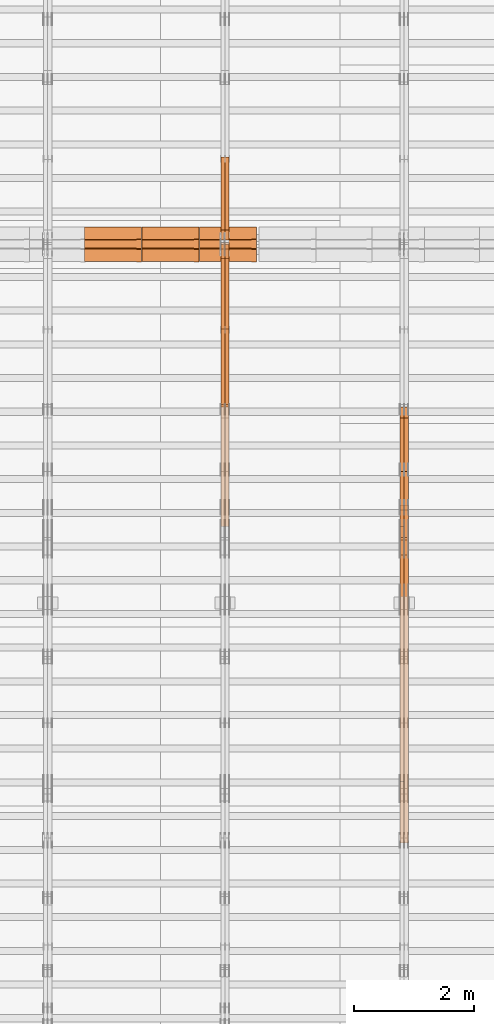
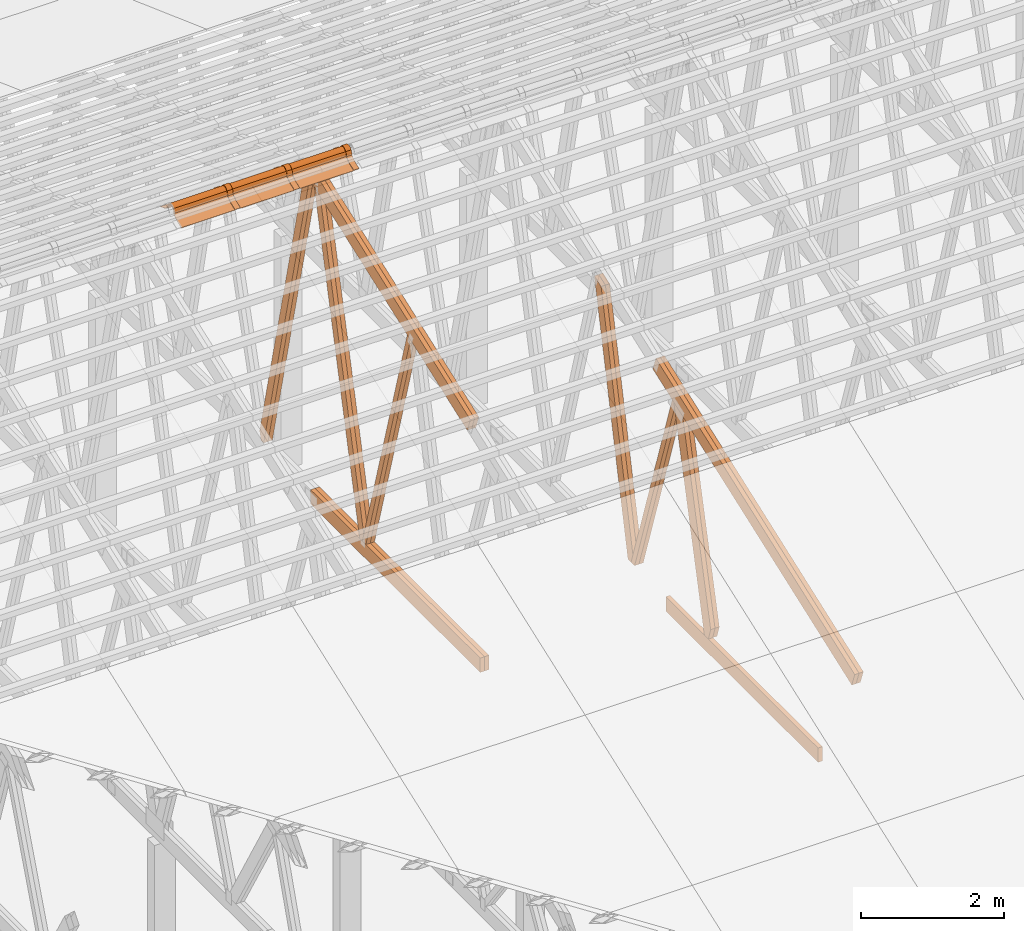
# One storey, part 19 of 189: 25 proxies.
"""IFC2X3 building model written with IfcOpenShell, lengths in millimetres."""

from ifc_helpers import new_model, entity, si_unit, converted_unit, derived_unit, direction, frame, frame_2d, origin, origin_2d_with_axis, place, context, subcontext, project, spatial, polyline, circle_curve, parameter, trimmed, segment, composite_curve, rectangle, outline, extrude, source, transform, mapped, material, type_object, type_shapes, element, save


model = new_model("IFC2X3")

# Units and contexts
model_context = context("Model", 3, precision=0.01, world=origin(), true_north=direction((6.12303176911189e-17, 1.0)))
body_context = subcontext(model_context, "Body", "Model", "MODEL_VIEW")
ifc_project = project(units=[si_unit("LENGTHUNIT", "METRE", prefix="MILLI"), si_unit("AREAUNIT", "SQUARE_METRE"), si_unit("VOLUMEUNIT", "CUBIC_METRE"), converted_unit("PLANEANGLEUNIT", "DEGREE", entity("IfcRatioMeasure", 0.0174532925199433), si_unit("PLANEANGLEUNIT", "RADIAN"), dimensions=[0, 0, 0, 0, 0, 0, 0]), si_unit("MASSUNIT", "GRAM", prefix="KILO"), derived_unit("MASSDENSITYUNIT", [(si_unit("MASSUNIT", "GRAM", prefix="KILO"), 1), (si_unit("LENGTHUNIT", "METRE"), -3)]), si_unit("TIMEUNIT", "SECOND"), si_unit("FREQUENCYUNIT", "HERTZ"), si_unit("THERMODYNAMICTEMPERATUREUNIT", "DEGREE_CELSIUS"), derived_unit("THERMALTRANSMITTANCEUNIT", [(si_unit("MASSUNIT", "GRAM", prefix="KILO"), 1), (si_unit("THERMODYNAMICTEMPERATUREUNIT", "KELVIN"), -1), (si_unit("TIMEUNIT", "SECOND"), -3)]), derived_unit("VOLUMETRICFLOWRATEUNIT", [(si_unit("LENGTHUNIT", "METRE"), 3), (si_unit("TIMEUNIT", "SECOND"), -1)]), si_unit("ELECTRICCURRENTUNIT", "AMPERE"), si_unit("ELECTRICVOLTAGEUNIT", "VOLT"), si_unit("POWERUNIT", "WATT"), si_unit("FORCEUNIT", "NEWTON"), si_unit("ILLUMINANCEUNIT", "LUX"), si_unit("LUMINOUSFLUXUNIT", "LUMEN"), si_unit("LUMINOUSINTENSITYUNIT", "CANDELA"), derived_unit("USERDEFINED", [(si_unit("MASSUNIT", "GRAM", prefix="KILO"), -1), (si_unit("LENGTHUNIT", "METRE"), -2), (si_unit("TIMEUNIT", "SECOND"), 3), (si_unit("LUMINOUSFLUXUNIT", "LUMEN"), 1)]), derived_unit("LINEARVELOCITYUNIT", [(si_unit("LENGTHUNIT", "METRE"), 1), (si_unit("TIMEUNIT", "SECOND"), -1)]), si_unit("PRESSUREUNIT", "PASCAL"), derived_unit("USERDEFINED", [(si_unit("LENGTHUNIT", "METRE"), -2), (si_unit("MASSUNIT", "GRAM", prefix="KILO"), 1), (si_unit("TIMEUNIT", "SECOND"), -2)])], contexts=[model_context])

# Site, building, storey
site_placement = place(None, origin())
site = spatial("IfcSite", under=ifc_project, at=site_placement, CompositionType="ELEMENT")
building_placement = place(site_placement, origin())
building = spatial("IfcBuilding", under=site, at=building_placement, CompositionType="ELEMENT")
storey_placement = place(building_placement, origin())
storey = spatial("IfcBuildingStorey", under=building, at=storey_placement, Name="Default", CompositionType="ELEMENT", Elevation=0.0)

# Proxies
ifc_material_1 = material(Name="IfcSurfaceStyle #68106")
building_element_proxy_type_1 = type_object("IfcBuildingElementProxyType", Name="T1-W3 68104", PredefinedType="NOTDEFINED", material=ifc_material_1)
shared_shape_1 = source(origin(), body_context, "Body", "SweptSolid", [
    extrude(outline(polyline([(-2625.55080717397, -84.9998286237256), (1749.48871563991, -84.9998286237256), (1768.20584427244, 0.000602085469291858), (1625.445846867, 85.0000405971208), (-2517.58959960538, 84.9990145648612), (-2625.55080717397, -84.9998286237256)])), frame((1768.20584427244, 85.0000405971208, 0.0), z_axis=(0.0, 0.0, 1.0), x_axis=(-1.0, 0.0, 0.0)), (0.0, 0.0, 1.0), 69.9999999999997),
])
type_shapes(building_element_proxy_type_1, [shared_shape_1])
proxy_1_placement = place(building_placement, frame((12300.0, 10918.6728403286, 263.278932236374), z_axis=(-1.0, 0.0, 0.0), x_axis=(0.0, 0.215047682154604, 0.976603550269982)))
element("IfcBuildingElementProxy", 1, at=proxy_1_placement, inside=storey, type_object=building_element_proxy_type_1, material=ifc_material_1, Name="T1-W3", context=body_context, shape_type="MappedRepresentation", body=[
    mapped(shared_shape_1, transform((0.0, 0.0, 0.0), scale=1.0)),
])
ifc_material_2 = material(Name="IfcSurfaceStyle #68040")
building_element_proxy_type_2 = type_object("IfcBuildingElementProxyType", Name="T1-W3 68038", PredefinedType="NOTDEFINED", material=ifc_material_2)
shared_shape_2 = source(origin(), body_context, "Body", "SweptSolid", [
    extrude(outline(polyline([(-2625.55080717397, -84.9998286237256), (1749.48871563991, -84.9998286237256), (1768.20584427244, 0.000602085469291858), (1625.445846867, 85.0000405971208), (-2517.58959960538, 84.9990145648612), (-2625.55080717397, -84.9998286237256)])), frame((1768.20584427244, 85.0000405971208, 0.0), z_axis=(0.0, 0.0, 1.0), x_axis=(-1.0, 0.0, 0.0)), (0.0, 0.0, 1.0), 69.9999999999997),
])
type_shapes(building_element_proxy_type_2, [shared_shape_2])
proxy_2_placement = place(building_placement, frame((12230.0, 10918.6728403286, 263.278932236374), z_axis=(-1.0, 0.0, 0.0), x_axis=(0.0, 0.215047682154604, 0.976603550269982)))
element("IfcBuildingElementProxy", 2, at=proxy_2_placement, inside=storey, type_object=building_element_proxy_type_2, material=ifc_material_2, Name="T1-W3", context=body_context, shape_type="MappedRepresentation", body=[
    mapped(shared_shape_2, transform((0.0, 0.0, 0.0), scale=1.0)),
])
ifc_material_3 = material(Name="IfcSurfaceStyle #67842")
building_element_proxy_type_3 = type_object("IfcBuildingElementProxyType", Name="T1-W7 67840", PredefinedType="NOTDEFINED", material=ifc_material_3)
shared_shape_3 = source(origin(), body_context, "Body", "SweptSolid", [
    extrude(outline(polyline([(-2158.15323194511, -47.5001976605119), (1398.58481981178, -47.5001976605119), (1473.93376219819, -0.000131511554346808), (1475.30069254941, 47.5002634162891), (-2189.66604261427, 47.5002634162891), (-2158.15323194511, -47.5001976605119)])), frame((1475.30069254941, 47.5002634162891, 0.0), z_axis=(0.0, 0.0, 1.0), x_axis=(-1.0, 0.0, 0.0)), (0.0, 0.0, 1.0), 69.9999999999998),
])
type_shapes(building_element_proxy_type_3, [shared_shape_3])
proxy_3_placement = place(building_placement, frame((12300.0, 9847.787109375, 3723.57788085937), z_axis=(-1.0, 0.0, 0.0), x_axis=(0.0, 0.314845237923105, -0.949143021971475)))
element("IfcBuildingElementProxy", 3, at=proxy_3_placement, inside=storey, type_object=building_element_proxy_type_3, material=ifc_material_3, Name="T1-W7", context=body_context, shape_type="MappedRepresentation", body=[
    mapped(shared_shape_3, transform((0.0, 0.0, 0.0), scale=1.0)),
])
ifc_material_4 = material(Name="IfcSurfaceStyle #67776")
building_element_proxy_type_4 = type_object("IfcBuildingElementProxyType", Name="T1-W7 67774", PredefinedType="NOTDEFINED", material=ifc_material_4)
shared_shape_4 = source(origin(), body_context, "Body", "SweptSolid", [
    extrude(outline(polyline([(-2158.15323194511, -47.5001976605119), (1398.58481981178, -47.5001976605119), (1473.93376219819, -0.000131511554346808), (1475.30069254941, 47.5002634162891), (-2189.66604261427, 47.5002634162891), (-2158.15323194511, -47.5001976605119)])), frame((1475.30069254941, 47.5002634162891, 0.0), z_axis=(0.0, 0.0, 1.0), x_axis=(-1.0, 0.0, 0.0)), (0.0, 0.0, 1.0), 69.9999999999998),
])
type_shapes(building_element_proxy_type_4, [shared_shape_4])
proxy_4_placement = place(building_placement, frame((12230.0, 9847.787109375, 3723.57788085937), z_axis=(-1.0, 0.0, 0.0), x_axis=(0.0, 0.314845237923105, -0.949143021971475)))
element("IfcBuildingElementProxy", 4, at=proxy_4_placement, inside=storey, type_object=building_element_proxy_type_4, material=ifc_material_4, Name="T1-W7", context=body_context, shape_type="MappedRepresentation", body=[
    mapped(shared_shape_4, transform((0.0, 0.0, 0.0), scale=1.0)),
])
ifc_material_5 = material(Name="IfcSurfaceStyle #67578")
building_element_proxy_type_5 = type_object("IfcBuildingElementProxyType", Name="T1-W1 67576", PredefinedType="NOTDEFINED", material=ifc_material_5)
shared_shape_5 = source(origin(), body_context, "Body", "SweptSolid", [
    extrude(outline(polyline([(-2144.69382208629, -109.99948311278), (1421.70798092021, -109.99948311278), (1448.88116133745, -0.000392715405943322), (1271.09900468242, 109.999679470483), (-1996.99432485378, 109.999679470483), (-2144.69382208629, -109.99948311278)])), frame((1448.88130194731, 110.000176487146, 0.0), z_axis=(0.0, 0.0, 1.0), x_axis=(-1.0, 0.0, 0.0)), (0.0, 0.0, 1.0), 69.9999999999998),
])
type_shapes(building_element_proxy_type_5, [shared_shape_5])
proxy_5_placement = place(building_placement, frame((12300.0, 8727.74270166583, 271.380182391418), z_axis=(-1.0, 0.0, 0.0), x_axis=(0.0, 0.239819839925978, 0.970817410421691)))
element("IfcBuildingElementProxy", 5, at=proxy_5_placement, inside=storey, type_object=building_element_proxy_type_5, material=ifc_material_5, Name="T1-W1", context=body_context, shape_type="MappedRepresentation", body=[
    mapped(shared_shape_5, transform((0.0, 0.0, 0.0), scale=1.0)),
])
ifc_material_6 = material(Name="IfcSurfaceStyle #67512")
building_element_proxy_type_6 = type_object("IfcBuildingElementProxyType", Name="T1-W1 67510", PredefinedType="NOTDEFINED", material=ifc_material_6)
shared_shape_6 = source(origin(), body_context, "Body", "SweptSolid", [
    extrude(outline(polyline([(-2144.69382208629, -109.99948311278), (1421.70798092021, -109.99948311278), (1448.88116133745, -0.000392715405943322), (1271.09900468242, 109.999679470483), (-1996.99432485378, 109.999679470483), (-2144.69382208629, -109.99948311278)])), frame((1448.88130194731, 110.000176487146, 0.0), z_axis=(0.0, 0.0, 1.0), x_axis=(-1.0, 0.0, 0.0)), (0.0, 0.0, 1.0), 69.9999999999998),
])
type_shapes(building_element_proxy_type_6, [shared_shape_6])
proxy_6_placement = place(building_placement, frame((12230.0, 8727.74270166583, 271.380182391418), z_axis=(-1.0, 0.0, 0.0), x_axis=(0.0, 0.239819839925978, 0.970817410421691)))
element("IfcBuildingElementProxy", 6, at=proxy_6_placement, inside=storey, type_object=building_element_proxy_type_6, material=ifc_material_6, Name="T1-W1", context=body_context, shape_type="MappedRepresentation", body=[
    mapped(shared_shape_6, transform((0.0, 0.0, 0.0), scale=1.0)),
])
ifc_material_7 = material(Name="IfcSurfaceStyle #64179")
building_element_proxy_type_7 = type_object("IfcBuildingElementProxyType", Name="T1-B6 64177", PredefinedType="NOTDEFINED", material=ifc_material_7)
shared_shape_7 = source(origin(), body_context, "Body", "SweptSolid", [
    extrude(rectangle(XDim=4266.763671875, YDim=245.000000000001, at=origin_2d_with_axis()), frame((2133.3818359375, 122.500000000001, 0.0), z_axis=(0.0, 0.0, 1.0), x_axis=(-1.0, 0.0, 0.0)), (0.0, 0.0, 1.0), 69.9999999999997),
])
type_shapes(building_element_proxy_type_7, [shared_shape_7])
proxy_7_placement = place(building_placement, frame((12230.0, 5762.466796875, 245.0), z_axis=(-1.0, 0.0, 0.0), x_axis=(0.0, 1.0, 0.0)))
element("IfcBuildingElementProxy", 7, at=proxy_7_placement, inside=storey, type_object=building_element_proxy_type_7, material=ifc_material_7, Name="T1-B6", context=body_context, shape_type="MappedRepresentation", body=[
    mapped(shared_shape_7, transform((0.0, 0.0, 0.0), scale=1.0)),
])
ifc_material_8 = material(Name="IfcSurfaceStyle #63876")
building_element_proxy_type_8 = type_object("IfcBuildingElementProxyType", Name="T1-T1 63874", PredefinedType="NOTDEFINED", material=ifc_material_8)
shared_shape_8 = source(origin(), body_context, "Body", "SweptSolid", [
    extrude(outline(polyline([(-2964.99981923522, -122.500027388895), (2964.99982426074, -122.500027388895), (2964.99984011048, 122.500027388895), (-2964.99984513599, 122.500027388895), (-2964.99981923522, -122.500027388895)])), frame((2965.00021857317, 122.500056320695, 0.0), z_axis=(0.0, 0.0, 1.0), x_axis=(-1.0, 0.0, 0.0)), (0.0, 0.0, 1.0), 69.9999999999996),
])
type_shapes(building_element_proxy_type_8, [shared_shape_8])
proxy_8_placement = place(building_placement, frame((12300.0, 10391.0374749089, 3921.30478975487), z_axis=(-1.0, 0.0, 0.0), x_axis=(0.0, -0.939692620785908, -0.342020143325669)))
element("IfcBuildingElementProxy", 8, at=proxy_8_placement, inside=storey, type_object=building_element_proxy_type_8, material=ifc_material_8, Name="T1-T1", context=body_context, shape_type="MappedRepresentation", body=[
    mapped(shared_shape_8, transform((0.0, 0.0, 0.0), scale=1.0)),
])
ifc_material_9 = material(Name="IfcSurfaceStyle #63819")
building_element_proxy_type_9 = type_object("IfcBuildingElementProxyType", Name="T1-T1 63817", PredefinedType="NOTDEFINED", material=ifc_material_9)
shared_shape_9 = source(origin(), body_context, "Body", "SweptSolid", [
    extrude(outline(polyline([(-2964.99981923522, -122.500027388895), (2964.99982426074, -122.500027388895), (2964.99984011048, 122.500027388895), (-2964.99984513599, 122.500027388895), (-2964.99981923522, -122.500027388895)])), frame((2965.00021857317, 122.500056320695, 0.0), z_axis=(0.0, 0.0, 1.0), x_axis=(-1.0, 0.0, 0.0)), (0.0, 0.0, 1.0), 69.9999999999996),
])
type_shapes(building_element_proxy_type_9, [shared_shape_9])
proxy_9_placement = place(building_placement, frame((12230.0, 10391.0374749089, 3921.30478975487), z_axis=(-1.0, 0.0, 0.0), x_axis=(0.0, -0.939692620785908, -0.342020143325669)))
element("IfcBuildingElementProxy", 9, at=proxy_9_placement, inside=storey, type_object=building_element_proxy_type_9, material=ifc_material_9, Name="T1-T1", context=body_context, shape_type="MappedRepresentation", body=[
    mapped(shared_shape_9, transform((0.0, 0.0, 0.0), scale=1.0)),
])
ifc_material_10 = material(Name="IfcSurfaceStyle #52844")
building_element_proxy_type_10 = type_object("IfcBuildingElementProxyType", Name="T1-W5 52842", PredefinedType="NOTDEFINED", material=ifc_material_10)
shared_shape_10 = source(origin(), body_context, "Body", "SweptSolid", [
    extrude(outline(polyline([(-3233.61216530572, -72.4999091305202), (2153.79187521892, -72.4999091305202), (2171.36968478227, -7.18521572819375e-05), (2045.62106208646, 72.4999450565989), (-3137.17045678193, 72.4999450565989), (-3233.61216530572, -72.4999091305202)])), frame((2171.36968478227, 72.500192121173, 0.0), z_axis=(0.0, 0.0, 1.0), x_axis=(-1.0, 0.0, 0.0)), (0.0, 0.0, 1.0), 69.9999999999997),
])
type_shapes(building_element_proxy_type_10, [shared_shape_10])
proxy_10_placement = place(building_placement, frame((9300.0, 13261.0146935344, 262.082919891325), z_axis=(-1.0, 0.0, 0.0), x_axis=(0.0, 0.235625623344066, 0.97184389982328)))
element("IfcBuildingElementProxy", 10, at=proxy_10_placement, inside=storey, type_object=building_element_proxy_type_10, material=ifc_material_10, Name="T1-W5", context=body_context, shape_type="MappedRepresentation", body=[
    mapped(shared_shape_10, transform((0.0, 0.0, 0.0), scale=1.0)),
])
ifc_material_11 = material(Name="IfcSurfaceStyle #52778")
building_element_proxy_type_11 = type_object("IfcBuildingElementProxyType", Name="T1-W5 52776", PredefinedType="NOTDEFINED", material=ifc_material_11)
shared_shape_11 = source(origin(), body_context, "Body", "SweptSolid", [
    extrude(outline(polyline([(-3233.61216530572, -72.4999091305202), (2153.79187521892, -72.4999091305202), (2171.36968478227, -7.18521572819375e-05), (2045.62106208646, 72.4999450565989), (-3137.17045678193, 72.4999450565989), (-3233.61216530572, -72.4999091305202)])), frame((2171.36968478227, 72.500192121173, 0.0), z_axis=(0.0, 0.0, 1.0), x_axis=(-1.0, 0.0, 0.0)), (0.0, 0.0, 1.0), 69.9999999999997),
])
type_shapes(building_element_proxy_type_11, [shared_shape_11])
proxy_11_placement = place(building_placement, frame((9230.0, 13261.0146935344, 262.082919891325), z_axis=(-1.0, 0.0, 0.0), x_axis=(0.0, 0.235625623344066, 0.97184389982328)))
element("IfcBuildingElementProxy", 11, at=proxy_11_placement, inside=storey, type_object=building_element_proxy_type_11, material=ifc_material_11, Name="T1-W5", context=body_context, shape_type="MappedRepresentation", body=[
    mapped(shared_shape_11, transform((0.0, 0.0, 0.0), scale=1.0)),
])
ifc_material_12 = material(Name="IfcSurfaceStyle #52712")
building_element_proxy_type_12 = type_object("IfcBuildingElementProxyType", Name="T1-W5 52710", PredefinedType="NOTDEFINED", material=ifc_material_12)
shared_shape_12 = source(origin(), body_context, "Body", "SweptSolid", [
    extrude(outline(polyline([(-3137.17045678193, -72.5002081306407), (2045.62106208646, -72.5002081306408), (2171.36968478227, 5.58426931168476e-05), (2153.79187521892, 72.5001802092942), (-3233.61216530572, 72.5001802092942), (-3137.17045678193, -72.5002081306407)])), frame((2171.36968478227, 72.5001802092942, 0.0), z_axis=(0.0, 0.0, 1.0), x_axis=(-1.0, 0.0, 0.0)), (0.0, 0.0, 1.0), 69.9999999999997),
])
type_shapes(building_element_proxy_type_12, [shared_shape_12])
proxy_12_placement = place(building_placement, frame((9300.0, 16098.0675635854, 227.917113003597), z_axis=(-1.0, 0.0, 0.0), x_axis=(0.0, -0.235625623344066, 0.971843899823279)))
element("IfcBuildingElementProxy", 12, at=proxy_12_placement, inside=storey, type_object=building_element_proxy_type_12, material=ifc_material_12, Name="T1-W5", context=body_context, shape_type="MappedRepresentation", body=[
    mapped(shared_shape_12, transform((0.0, 0.0, 0.0), scale=1.0)),
])
ifc_material_13 = material(Name="IfcSurfaceStyle #52646")
building_element_proxy_type_13 = type_object("IfcBuildingElementProxyType", Name="T1-W5 52644", PredefinedType="NOTDEFINED", material=ifc_material_13)
shared_shape_13 = source(origin(), body_context, "Body", "SweptSolid", [
    extrude(outline(polyline([(-3137.17045678193, -72.5002081306407), (2045.62106208646, -72.5002081306408), (2171.36968478227, 5.58426931168476e-05), (2153.79187521892, 72.5001802092942), (-3233.61216530572, 72.5001802092942), (-3137.17045678193, -72.5002081306407)])), frame((2171.36968478227, 72.5001802092942, 0.0), z_axis=(0.0, 0.0, 1.0), x_axis=(-1.0, 0.0, 0.0)), (0.0, 0.0, 1.0), 69.9999999999997),
])
type_shapes(building_element_proxy_type_13, [shared_shape_13])
proxy_13_placement = place(building_placement, frame((9230.0, 16098.0675635854, 227.917113003597), z_axis=(-1.0, 0.0, 0.0), x_axis=(0.0, -0.235625623344066, 0.971843899823279)))
element("IfcBuildingElementProxy", 13, at=proxy_13_placement, inside=storey, type_object=building_element_proxy_type_13, material=ifc_material_13, Name="T1-W5", context=body_context, shape_type="MappedRepresentation", body=[
    mapped(shared_shape_13, transform((0.0, 0.0, 0.0), scale=1.0)),
])
ifc_material_14 = material(Name="IfcSurfaceStyle #52580")
building_element_proxy_type_14 = type_object("IfcBuildingElementProxyType", Name="T1-W6 52578", PredefinedType="NOTDEFINED", material=ifc_material_14)
shared_shape_14 = source(origin(), body_context, "Body", "SweptSolid", [
    extrude(outline(polyline([(-2640.84340836012, -47.4996765865792), (1711.12245024294, -47.4996765865792), (1797.68490303083, -9.57690019346202e-05), (1800.72595169379, 47.4997244710801), (-2668.68989660745, 47.4997244710801), (-2640.84340836012, -47.4996765865792)])), frame((1800.72595169379, 47.5003009358159, 0.0), z_axis=(0.0, 0.0, 1.0), x_axis=(-1.0, 0.0, 0.0)), (0.0, 0.0, 1.0), 69.9999999999997),
])
type_shapes(building_element_proxy_type_14, [shared_shape_14])
proxy_14_placement = place(building_placement, frame((9300.0, 12074.2896156894, 4533.9586582452), z_axis=(-1.0, 0.0, 0.0), x_axis=(0.0, 0.28128598310461, -0.959623986626467)))
element("IfcBuildingElementProxy", 14, at=proxy_14_placement, inside=storey, type_object=building_element_proxy_type_14, material=ifc_material_14, Name="T1-W6", context=body_context, shape_type="MappedRepresentation", body=[
    mapped(shared_shape_14, transform((0.0, 0.0, 0.0), scale=1.0)),
])
ifc_material_15 = material(Name="IfcSurfaceStyle #52514")
building_element_proxy_type_15 = type_object("IfcBuildingElementProxyType", Name="T1-W6 52512", PredefinedType="NOTDEFINED", material=ifc_material_15)
shared_shape_15 = source(origin(), body_context, "Body", "SweptSolid", [
    extrude(outline(polyline([(-2640.84340836012, -47.4996765865792), (1711.12245024294, -47.4996765865792), (1797.68490303083, -9.57690019346202e-05), (1800.72595169379, 47.4997244710801), (-2668.68989660745, 47.4997244710801), (-2640.84340836012, -47.4996765865792)])), frame((1800.72595169379, 47.5003009358159, 0.0), z_axis=(0.0, 0.0, 1.0), x_axis=(-1.0, 0.0, 0.0)), (0.0, 0.0, 1.0), 69.9999999999997),
])
type_shapes(building_element_proxy_type_15, [shared_shape_15])
proxy_15_placement = place(building_placement, frame((9230.0, 12074.2896156894, 4533.9586582452), z_axis=(-1.0, 0.0, 0.0), x_axis=(0.0, 0.28128598310461, -0.959623986626467)))
element("IfcBuildingElementProxy", 15, at=proxy_15_placement, inside=storey, type_object=building_element_proxy_type_15, material=ifc_material_15, Name="T1-W6", context=body_context, shape_type="MappedRepresentation", body=[
    mapped(shared_shape_15, transform((0.0, 0.0, 0.0), scale=1.0)),
])
ifc_material_16 = material(Name="IfcSurfaceStyle #48560")
building_element_proxy_type_16 = type_object("IfcBuildingElementProxyType", Name="T1-B3 48558", PredefinedType="NOTDEFINED", material=ifc_material_16)
shared_shape_16 = source(origin(), body_context, "Body", "SweptSolid", [
    extrude(rectangle(XDim=4751.0283203125, YDim=245.000000000001, at=origin_2d_with_axis()), frame((2375.51416015625, 122.5, 0.0), z_axis=(0.0, 0.0, 1.0), x_axis=(-1.0, 0.0, 0.0)), (0.0, 0.0, 1.0), 69.9999999999997),
])
type_shapes(building_element_proxy_type_16, [shared_shape_16])
proxy_16_placement = place(building_placement, frame((9300.0, 10029.23046875, 245.0), z_axis=(-1.0, 0.0, 0.0), x_axis=(0.0, 1.0, 0.0)))
element("IfcBuildingElementProxy", 16, at=proxy_16_placement, inside=storey, type_object=building_element_proxy_type_16, material=ifc_material_16, Name="T1-B3", context=body_context, shape_type="MappedRepresentation", body=[
    mapped(shared_shape_16, transform((0.0, 0.0, 0.0), scale=1.0)),
])
ifc_material_17 = material(Name="IfcSurfaceStyle #48503")
building_element_proxy_type_17 = type_object("IfcBuildingElementProxyType", Name="T1-B3 48501", PredefinedType="NOTDEFINED", material=ifc_material_17)
shared_shape_17 = source(origin(), body_context, "Body", "SweptSolid", [
    extrude(rectangle(XDim=4751.0283203125, YDim=245.000000000001, at=origin_2d_with_axis()), frame((2375.51416015625, 122.5, 0.0), z_axis=(0.0, 0.0, 1.0), x_axis=(-1.0, 0.0, 0.0)), (0.0, 0.0, 1.0), 69.9999999999997),
])
type_shapes(building_element_proxy_type_17, [shared_shape_17])
proxy_17_placement = place(building_placement, frame((9230.0, 10029.23046875, 245.0), z_axis=(-1.0, 0.0, 0.0), x_axis=(0.0, 1.0, 0.0)))
element("IfcBuildingElementProxy", 17, at=proxy_17_placement, inside=storey, type_object=building_element_proxy_type_17, material=ifc_material_17, Name="T1-B3", context=body_context, shape_type="MappedRepresentation", body=[
    mapped(shared_shape_17, transform((0.0, 0.0, 0.0), scale=1.0)),
])
ifc_material_18 = material(Name="IfcSurfaceStyle #47972")
building_element_proxy_type_18 = type_object("IfcBuildingElementProxyType", Name="T1-T3 47970", PredefinedType="NOTDEFINED", material=ifc_material_18)
shared_shape_18 = source(origin(), body_context, "Body", "SweptSolid", [
    extrude(outline(polyline([(-2341.64890001385, -122.499972785692), (2386.23525922045, -122.499972785692), (2297.06252495753, 122.499972785692), (-2341.64888416412, 122.499972785692), (-2341.64890001385, -122.499972785692)])), frame((2386.23525922045, 122.499973888764, 0.0), z_axis=(0.0, 0.0, 1.0), x_axis=(-1.0, 0.0, 0.0)), (0.0, 0.0, 1.0), 69.9999999999997),
])
type_shapes(building_element_proxy_type_18, [shared_shape_18])
proxy_18_placement = place(building_placement, frame((9300.0, 14833.7949607394, 5538.33627266055), z_axis=(-1.0, 0.0, 0.0), x_axis=(0.0, -0.939692620785908, -0.342020143325669)))
element("IfcBuildingElementProxy", 18, at=proxy_18_placement, inside=storey, type_object=building_element_proxy_type_18, material=ifc_material_18, Name="T1-T3", context=body_context, shape_type="MappedRepresentation", body=[
    mapped(shared_shape_18, transform((0.0, 0.0, 0.0), scale=1.0)),
])
ifc_material_19 = material(Name="IfcSurfaceStyle #47915")
building_element_proxy_type_19 = type_object("IfcBuildingElementProxyType", Name="T1-T3 47913", PredefinedType="NOTDEFINED", material=ifc_material_19)
shared_shape_19 = source(origin(), body_context, "Body", "SweptSolid", [
    extrude(outline(polyline([(-2341.64890001385, -122.499972785692), (2386.23525922045, -122.499972785692), (2297.06252495753, 122.499972785692), (-2341.64888416412, 122.499972785692), (-2341.64890001385, -122.499972785692)])), frame((2386.23525922045, 122.499973888764, 0.0), z_axis=(0.0, 0.0, 1.0), x_axis=(-1.0, 0.0, 0.0)), (0.0, 0.0, 1.0), 69.9999999999997),
])
type_shapes(building_element_proxy_type_19, [shared_shape_19])
proxy_19_placement = place(building_placement, frame((9230.0, 14833.7949607394, 5538.33627266055), z_axis=(-1.0, 0.0, 0.0), x_axis=(0.0, -0.939692620785908, -0.342020143325669)))
element("IfcBuildingElementProxy", 19, at=proxy_19_placement, inside=storey, type_object=building_element_proxy_type_19, material=ifc_material_19, Name="T1-T3", context=body_context, shape_type="MappedRepresentation", body=[
    mapped(shared_shape_19, transform((0.0, 0.0, 0.0), scale=1.0)),
])
ifc_material_20 = material()
building_element_proxy_type_20 = type_object("IfcBuildingElementProxyType", Name="P75", PredefinedType="NOTDEFINED", material=ifc_material_20)
shared_shape_20 = source(origin(), body_context, "Body", "SweptSolid", [
    extrude(outline(composite_curve([segment(polyline([(-69.4623915065845, -4.60763114971976), (47.4521071665907, -4.60763114971981)]), True, "CONTINUOUS"), segment(trimmed(circle_curve(frame_2d((119.940978060963, 14.6372018310859), x_axis=(-0.966518278591622, -0.256597773077395)), 75.0), [parameter(6.61555373744412e-13)], [parameter(180.0)], True, "PARAMETER"), True, "CONTINUOUS"), segment(polyline([(192.429848955335, 33.882034811891), (182.764666169419, 31.3160570811166)]), True, "CONTINUOUS"), segment(trimmed(circle_curve(frame_2d((119.940978060963, 14.6372018310859), x_axis=(-0.966518278591622, -0.256597773077395)), 65.0), [parameter(1.06866637297174e-12)], [parameter(180.0)], True, "PARAMETER"), False, "CONTINUOUS"), segment(polyline([(57.1172899525073, -2.04165341894578), (47.4521071665911, 5.39236885028051)]), True, "CONTINUOUS"), segment(polyline([(47.4521071665911, 5.39236885028052), (-70.7672243976422, 5.39236885028094)]), True, "CONTINUOUS"), segment(polyline([(-70.7672243976422, 5.39236885028094), (-194.776190618495, -27.5303655446341)]), True, "CONTINUOUS"), segment(polyline([(-194.776190618495, -27.5303655446341), (-192.210212887721, -37.1955483305503)]), True, "CONTINUOUS"), segment(polyline([(-192.210212887721, -37.1955483305503), (-69.4623915065845, -4.60763114971974)]), True, "CONTINUOUS")], self_intersect=False)), frame((0.0, 106.775760402721, -56.5599052870917), z_axis=(1.0, 0.0, 0.0), x_axis=(0.0, -0.820468487122275, 0.571691754041709)), (0.0, 0.0, 1.0), 867.000000000001),
    extrude(outline(composite_curve([segment(polyline([(62.2906866429439, -18.428943356533), (189.290686642944, -18.428943356533)]), True, "CONTINUOUS"), segment(polyline([(189.290686642944, -18.428943356533), (189.290686642944, -8.42894335653292)]), True, "CONTINUOUS"), segment(polyline([(189.290686642944, -8.42894335653292), (62.2906866429439, -8.42894335653294)]), True, "CONTINUOUS"), segment(polyline([(62.2906866429439, -8.42894335653294), (-41.0348065006093, 19.0026034957362)]), True, "CONTINUOUS"), segment(trimmed(circle_curve(frame_2d((-125.709313357056, 11.5710566434651), x_axis=(1.0, 0.0)), 85.0), [parameter(5.01577186738723)], [parameter(180.0)], True, "PARAMETER"), True, "CONTINUOUS"), segment(polyline([(-210.709313357056, 11.5710566434656), (-200.709313357056, 11.5710566434656)]), True, "CONTINUOUS"), segment(trimmed(circle_curve(frame_2d((-125.709313357056, 11.5710566434651), x_axis=(1.0, 0.0)), 75.0), [parameter(3.05333249420498e-13)], [parameter(180.0)], True, "PARAMETER"), False, "CONTINUOUS"), segment(polyline([(-50.7093133570542, 11.5710566434655), (62.290686642944, -18.4289433565322)]), True, "CONTINUOUS")], self_intersect=False)), frame((867.0, 114.170579674061, -53.8683539143053), z_axis=(1.0, 0.0, 0.0), x_axis=(0.0, 0.939692620785914, -0.342020143325653)), (0.0, 0.0, 1.0), 86.9999999999998),
])
type_shapes(building_element_proxy_type_20, [shared_shape_20])
for number, where, name in (
    (20, (8803.91649737545, 14755.0000438632, 5865.69618295448), "P75, generic model20:P75"),
    (21, (7843.91649737545, 14755.0000438632, 5865.69618295448), "P75, generic model20:P75"),
    (22, (6883.91649737545, 14755.0000438632, 5865.69618295448), "P75, generic model20:P75"),
):
    element("IfcBuildingElementProxy", number, at=place(storey_placement, frame(where)), inside=storey, type_object=building_element_proxy_type_20, material=ifc_material_20, Name=name, ObjectType="P75, generic model20:P75", context=body_context, shape_type="MappedRepresentation", body=[
        mapped(shared_shape_20, transform((0.0, 0.0, 0.0), scale=1.0)),
    ])
building_element_proxy_type_21 = type_object("IfcBuildingElementProxyType", Name="P75", PredefinedType="NOTDEFINED", material=ifc_material_20)
shared_shape_21 = source(origin(), body_context, "Body", "SweptSolid", [
    extrude(outline(composite_curve([segment(polyline([(68.3189789579817, 13.3705352460084), (195.318978957982, 13.3705352460084)]), True, "CONTINUOUS"), segment(polyline([(195.318978957982, 13.3705352460084), (195.318978957982, 23.3705352460084)]), True, "CONTINUOUS"), segment(polyline([(195.318978957982, 23.3705352460084), (67.014146066922, 23.3705352460088)]), True, "CONTINUOUS"), segment(polyline([(67.014146066922, 23.3705352460088), (-47.2469987727929, -6.96428196807339)]), True, "CONTINUOUS"), segment(polyline([(-47.2469987727929, -6.96428196807339), (-54.6810210420187, -16.62946475399)]), True, "CONTINUOUS"), segment(trimmed(circle_curve(frame_2d((-119.681021042019, -16.6294647539896), x_axis=(1.0, 0.0)), 65.0), [parameter(180.0)], [parameter(359.999999999999)], True, "PARAMETER"), False, "CONTINUOUS"), segment(polyline([(-184.681021042019, -16.6294647539905), (-194.681021042019, -16.6294647539901)]), True, "CONTINUOUS"), segment(trimmed(circle_curve(frame_2d((-119.681021042019, -16.6294647539896), x_axis=(1.0, 0.0)), 75.0), [parameter(180.0)], [parameter(359.999999999999)], True, "PARAMETER"), True, "CONTINUOUS"), segment(polyline([(-44.6810210420183, -16.6294647539898), (68.3189789579816, 13.3705352460083)]), True, "CONTINUOUS")], self_intersect=False)), frame((0.0, -106.775760402721, -56.5599052870916), z_axis=(1.0, 0.0, 0.0), x_axis=(0.0, -0.939692620785914, -0.342020143325654)), (0.0, 0.0, 1.0), 867.000000000001),
    extrude(outline(composite_curve([segment(polyline([(-64.9339130518847, 1.82825913317695), (-187.681734433021, -30.7596580476538)]), True, "CONTINUOUS"), segment(polyline([(-187.681734433021, -30.7596580476538), (-185.115756702247, -40.4248408335702)]), True, "CONTINUOUS"), segment(polyline([(-185.115756702247, -40.4248408335702), (-62.3679353211107, -7.83692365273935)]), True, "CONTINUOUS"), segment(polyline([(-62.3679353211107, -7.83692365273935), (44.5369162809878, -7.83692365273935)]), True, "CONTINUOUS"), segment(trimmed(circle_curve(frame_2d((124.469456515662, 21.0730921139827), x_axis=(-0.966518278591636, -0.256597773077402)), 85.0), [parameter(5.01577186738723)], [parameter(180.0)], True, "PARAMETER"), True, "CONTINUOUS"), segment(polyline([(206.623510195951, 42.8839028255618), (196.958327410034, 40.3179250947878)]), True, "CONTINUOUS"), segment(trimmed(circle_curve(frame_2d((124.469456515662, 21.0730921139827), x_axis=(-0.966518278591636, -0.256597773077402)), 75.0), [parameter(3.05333249420498e-13)], [parameter(180.0)], True, "PARAMETER"), False, "CONTINUOUS"), segment(polyline([(51.9805856212887, 1.82825913317622), (-64.9339130518846, 1.82825913317621)]), True, "CONTINUOUS")], self_intersect=False)), frame((867.0, -114.170579674061, -53.868353914305), z_axis=(-1.0, 0.0, 0.0), x_axis=(0.0, 0.820468487122275, 0.571691754041709)), (0.0, 0.0, -1.0), 86.9999999999998),
])
type_shapes(building_element_proxy_type_21, [shared_shape_21])
for number, where, name in (
    (23, (8803.91649737545, 14745.0000384614, 5850.69618295448), "P75, generic model20:P75"),
    (24, (7843.91649737545, 14745.0000384614, 5850.69618295448), "P75, generic model20:P75"),
    (25, (6883.91649737545, 14745.0000384614, 5850.69618295448), "P75, generic model20:P75"),
):
    element("IfcBuildingElementProxy", number, at=place(storey_placement, frame(where)), inside=storey, type_object=building_element_proxy_type_21, material=ifc_material_20, Name=name, ObjectType="P75, generic model20:P75", context=body_context, shape_type="MappedRepresentation", body=[
        mapped(shared_shape_21, transform((0.0, 0.0, 0.0), scale=1.0)),
    ])

save(model, "model.ifc")
